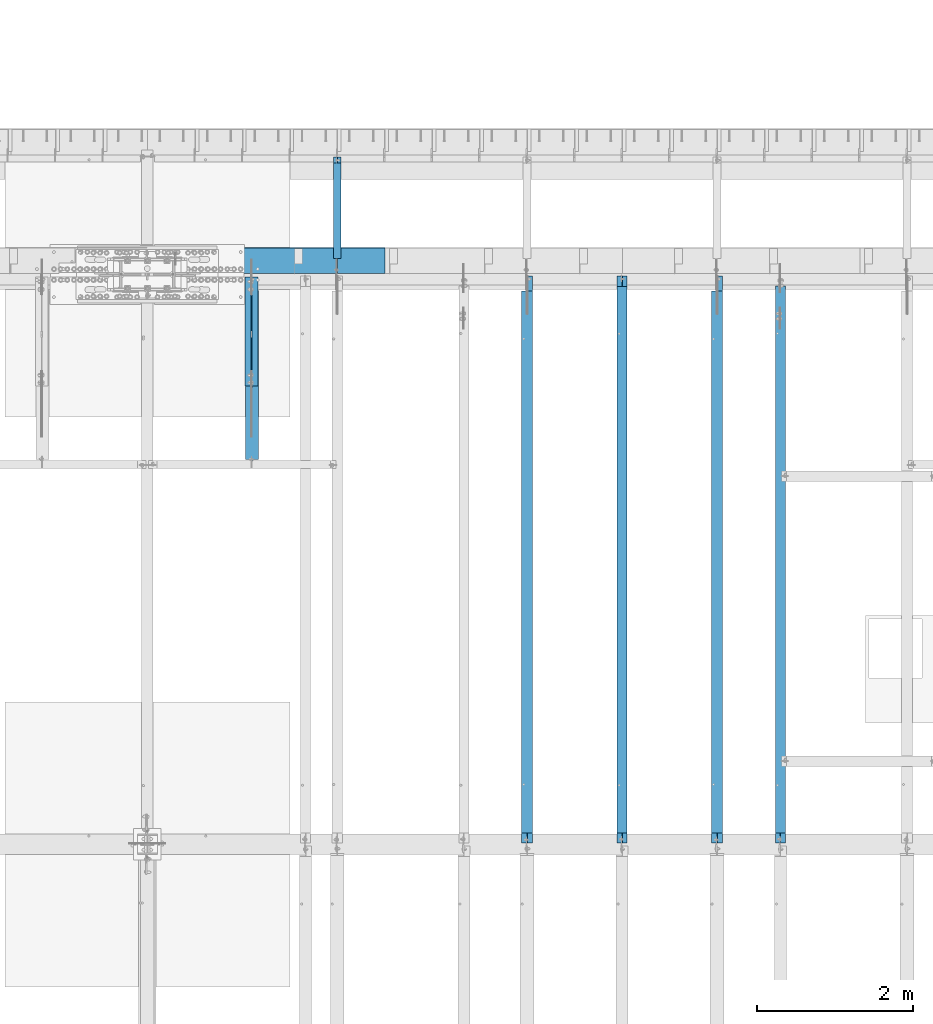
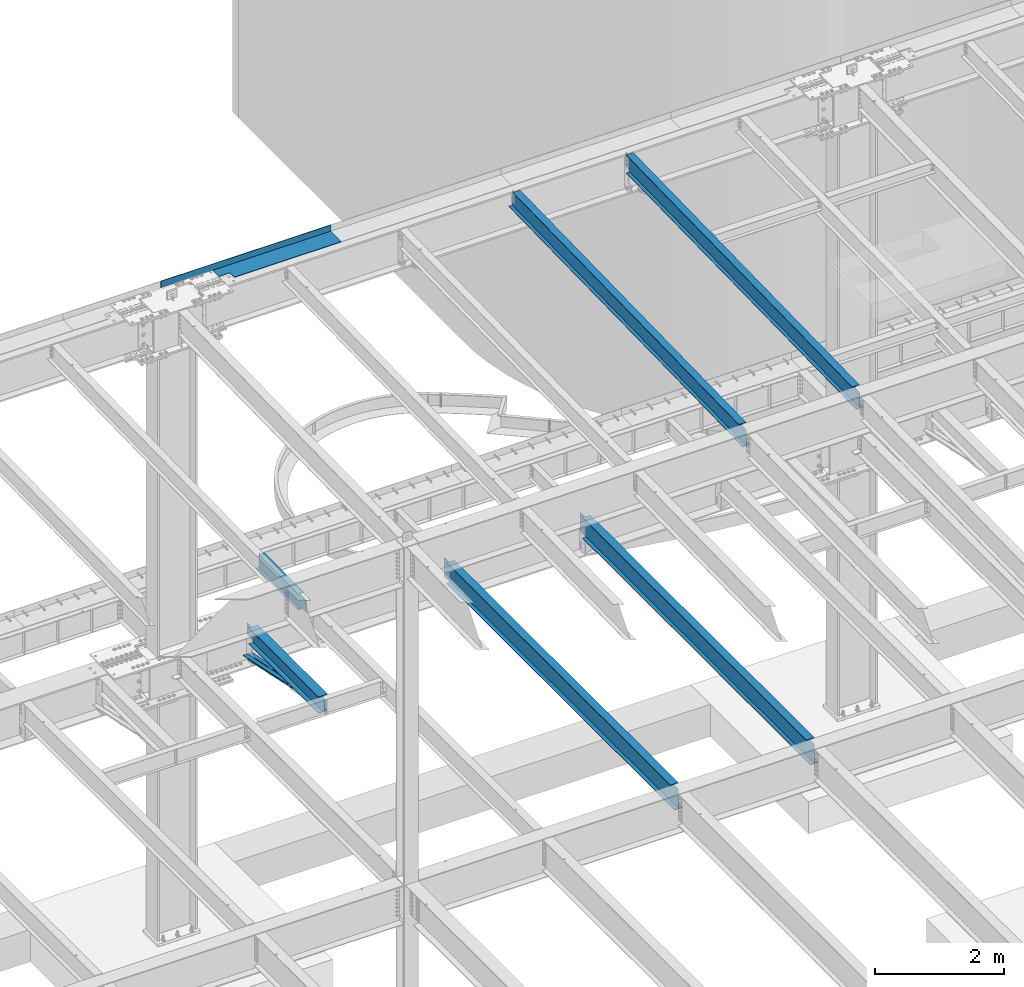
# One storey, part 1133 of 1763: 9 beams, 8 elements without a shape of their own.
"""IFC2X3 building model written with IfcOpenShell, lengths in millimetres."""

from ifc_helpers import new_model, si_unit, frame, origin_with_axes, place, context, subcontext, project, spatial, faceted_brep, material, type_object, element, aggregate, save


model = new_model("IFC2X3")

# Units and contexts
model_context = context("Model", 3, precision=1e-05, world=origin_with_axes())
body_context = subcontext(model_context, "Body", "Model", "MODEL_VIEW")
ifc_project = project(units=[si_unit("LENGTHUNIT", "METRE", prefix="MILLI"), si_unit("AREAUNIT", "SQUARE_METRE"), si_unit("VOLUMEUNIT", "CUBIC_METRE"), si_unit("MASSUNIT", "GRAM", prefix="KILO"), si_unit("TIMEUNIT", "SECOND"), si_unit("PLANEANGLEUNIT", "RADIAN"), si_unit("SOLIDANGLEUNIT", "STERADIAN"), si_unit("THERMODYNAMICTEMPERATUREUNIT", "DEGREE_CELSIUS"), si_unit("LUMINOUSINTENSITYUNIT", "LUMEN")], contexts=[model_context])

# Site, building, storey
site_placement = place(None, origin_with_axes())
site = spatial("IfcSite", under=ifc_project, at=site_placement, CompositionType="ELEMENT")
building_placement = place(site_placement, origin_with_axes())
building = spatial("IfcBuilding", under=site, at=building_placement, Name="Undefined", CompositionType="ELEMENT")
storey_placement = place(building_placement, origin_with_axes())
storey = spatial("IfcBuildingStorey", under=building, at=storey_placement, Name="Undefined", CompositionType="ELEMENT", Elevation=0.0)

# Assembly, beam
assembly_1_placement = place(storey_placement, origin_with_axes())
assembly_1 = element("IfcElementAssembly", 1, at=assembly_1_placement, inside=storey, Name="BEAM", AssemblyPlace="NOTDEFINED", PredefinedType="RIGID_FRAME")
ifc_material_1 = material(Name="STEEL/A992")
beam_type_1 = type_object("IfcBeamType", Name="W16X26", PredefinedType="NOTDEFINED")
beam_1_placement = place(assembly_1_placement, frame((-54279.2372736983, 44805.6, 4994.275), z_axis=(0.0, 0.0, 1.0), x_axis=(0.0, 1.0, 0.0)))
beam_1 = element("IfcBeam", 2, at=beam_1_placement, type_object=beam_type_1, material=ifc_material_1, Name="BEAM", ObjectType="W16X26", context=body_context, shape_type="Brep", body=[
    faceted_brep([(7104.06248869727, 3.17500000000291, -190.5), (7104.06248869734, 3.17487653380522, -200.025), (7104.06247902929, 69.8499999999985, -200.025), (7104.06247902929, 69.8499999999985, -190.5), (7294.5625, 3.17500000000291, -190.5), (7294.5625, 3.17490415680368, -200.025), (146.04999924302, 3.17499999999927, 190.5), (146.04999924302, 69.8499999999985, 190.5), (7104.0625, 69.8499999999985, 190.5), (7104.0625, 3.17500000000291, 190.5), (146.04999943226, -69.8499999999985, 200.025), (146.04999943226, 69.8499999999985, 200.025), (146.04999943226, 3.17500000000291, 180.715001487731), (146.04999943226, -3.17500000000291, 180.715001487731), (146.04999924302, -3.17499999999927, 190.5), (146.04999924302, -69.8499999999985, 190.5), (145.083269509669, 3.17500000000291, 175.854921969685), (145.083269509669, -3.17500000000291, 175.854921969685), (142.330255609195, 3.17500000000291, 171.734745501532), (142.330255609195, -3.17500000000291, 171.734745501532), (138.210079141041, 3.17500000000291, 168.981731601053), (138.210079141041, -3.17500000000291, 168.981731601053), (133.349999622995, 3.17500000000291, 168.015001678466), (133.349999622995, -3.17500000000291, 168.015001678466), (19.0499999999956, 3.17500000000291, 168.015001678466), (19.0499999999956, -3.17500000000291, 168.015001678466), (19.0499999999956, 3.17499999999927, -190.5), (19.0499999999956, 69.8499999999985, -190.5), (19.0499999999956, 69.8499999999985, -200.025), (19.0499999999956, -69.8499999999985, -200.025), (19.0499999999956, -69.8499999999985, -190.5), (19.0499999999956, -3.17499999999927, -190.5), (7294.5625, -69.8499999999985, -200.025), (7294.5625, -69.8499999999985, -190.5), (7294.5625, -3.17500000000291, -190.5), (7111.90242029122, -3.17500000000291, 156.541729922587), (7107.78224382307, -3.17500000000291, 159.294743823066), (7105.02922992258, -3.17500000000291, 163.414920291219), (7104.0625, -3.17500000000291, 168.274999809265), (7104.0625, -3.17500000000291, 190.5), (7294.5625, -3.17500000000291, 155.575), (7116.76249980927, -3.17500000000291, 155.575), (7104.0625, -69.8499999999985, 190.5), (7104.0625, -69.8499999999985, 200.025), (7104.0625, 69.8499999999985, 200.025), (7104.0625, 3.17500000000291, 168.274999809265), (7105.02922992258, 3.17500000000291, 163.414920291219), (7107.78224382307, 3.17500000000291, 159.294743823066), (7111.90242029122, 3.17500000000291, 156.541729922587), (7116.76249980927, 3.17500000000291, 155.575), (7294.5625, 3.17500000000291, 155.575), (7294.5625, 3.17500000000291, -184.976846570121)], [[[0, 1, 2, 3]], [[4, 5, 1, 0]], [[6, 7, 8, 9]], [[10, 11, 7, 6, 12, 13, 14, 15]], [[13, 12, 16, 17]], [[17, 16, 18, 19]], [[19, 18, 20, 21]], [[21, 20, 22, 23]], [[23, 22, 24, 25]], [[26, 27, 28, 29, 30, 31, 25, 24]], [[30, 29, 32, 33]], [[31, 30, 33, 34]], [[35, 36, 37, 38, 39, 14, 13, 17, 19, 21, 23, 25, 31, 34, 40, 41]], [[15, 14, 39, 42]], [[10, 15, 42, 43]], [[11, 10, 43, 44]], [[7, 11, 44, 8]], [[43, 42, 39, 38, 45, 9, 8, 44]], [[37, 46, 45, 38]], [[36, 47, 46, 37]], [[35, 48, 47, 36]], [[41, 49, 48, 35]], [[40, 50, 49, 41]], [[51, 4, 0, 26, 24, 22, 20, 18, 16, 12, 6, 9, 45, 46, 47, 48, 49, 50]], [[27, 26, 0, 3]], [[28, 27, 3, 2]], [[32, 29, 28, 2, 1, 5]], [[51, 50, 40, 34, 33, 32, 5, 4]]]),
])
aggregate(assembly_1, [beam_1])

assembly_2_placement = place(storey_placement, origin_with_axes())
assembly_2 = element("IfcElementAssembly", 3, at=assembly_2_placement, inside=storey, Name="BEAM", AssemblyPlace="NOTDEFINED", PredefinedType="RIGID_FRAME")
beam_2_placement = place(assembly_2_placement, frame((-56717.6372736983, 44805.6, 4994.275), z_axis=(0.0, 0.0, 1.0), x_axis=(0.0, 1.0, 0.0)))
beam_2 = element("IfcBeam", 4, at=beam_2_placement, type_object=beam_type_1, material=ifc_material_1, Name="BEAM", ObjectType="W16X26", context=body_context, shape_type="Brep", body=[
    faceted_brep([(7104.06248869727, 3.17500000000291, -190.5), (7104.06248869734, 3.17487653380522, -200.025), (7104.06247902929, 69.8499999999985, -200.025), (7104.06247902929, 69.8499999999985, -190.5), (7294.5625, 3.17500000000291, -190.5), (7294.5625, 3.17490415680368, -200.025), (146.04999924302, 3.17499999999927, 190.5), (146.04999924302, 69.8499999999985, 190.5), (7104.0625, 69.8499999999985, 190.5), (7104.0625, 3.17500000000291, 190.5), (146.04999943226, -69.8499999999985, 200.025), (146.04999943226, 69.8499999999985, 200.025), (146.04999943226, 3.17500000000291, 180.715001487731), (146.04999943226, -3.17500000000291, 180.715001487731), (146.04999924302, -3.17499999999927, 190.5), (146.04999924302, -69.8499999999985, 190.5), (145.083269509669, 3.17500000000291, 175.854921969685), (145.083269509669, -3.17500000000291, 175.854921969685), (142.330255609195, 3.17500000000291, 171.734745501532), (142.330255609195, -3.17500000000291, 171.734745501532), (138.210079141041, 3.17500000000291, 168.981731601053), (138.210079141041, -3.17500000000291, 168.981731601053), (133.349999622995, 3.17500000000291, 168.015001678466), (133.349999622995, -3.17500000000291, 168.015001678466), (19.0499999999956, 3.17500000000291, 168.015001678466), (19.0499999999956, -3.17500000000291, 168.015001678466), (19.0499999999956, 3.17499999999927, -190.5), (19.0499999999956, 69.8499999999985, -190.5), (19.0499999999956, 69.8499999999985, -200.025), (19.0499999999956, -69.8499999999985, -200.025), (19.0499999999956, -69.8499999999985, -190.5), (19.0499999999956, -3.17499999999927, -190.5), (7294.5625, -69.8499999999985, -200.025), (7294.5625, -69.8499999999985, -190.5), (7294.5625, -3.17500000000291, -190.5), (7111.90242029122, -3.17500000000291, 156.541729922587), (7107.78224382307, -3.17500000000291, 159.294743823066), (7105.02922992258, -3.17500000000291, 163.414920291219), (7104.0625, -3.17500000000291, 168.274999809265), (7104.0625, -3.17500000000291, 190.5), (7294.5625, -3.17500000000291, 155.575), (7116.76249980927, -3.17500000000291, 155.575), (7104.0625, -69.8499999999985, 190.5), (7104.0625, -69.8499999999985, 200.025), (7104.0625, 69.8499999999985, 200.025), (7104.0625, 3.17500000000291, 168.274999809265), (7105.02922992258, 3.17500000000291, 163.414920291219), (7107.78224382307, 3.17500000000291, 159.294743823066), (7111.90242029122, 3.17500000000291, 156.541729922587), (7116.76249980927, 3.17500000000291, 155.575), (7294.5625, 3.17500000000291, 155.575), (7294.5625, 3.17500000000291, -184.976846570121)], [[[0, 1, 2, 3]], [[4, 5, 1, 0]], [[6, 7, 8, 9]], [[10, 11, 7, 6, 12, 13, 14, 15]], [[13, 12, 16, 17]], [[17, 16, 18, 19]], [[19, 18, 20, 21]], [[21, 20, 22, 23]], [[23, 22, 24, 25]], [[26, 27, 28, 29, 30, 31, 25, 24]], [[30, 29, 32, 33]], [[31, 30, 33, 34]], [[35, 36, 37, 38, 39, 14, 13, 17, 19, 21, 23, 25, 31, 34, 40, 41]], [[15, 14, 39, 42]], [[10, 15, 42, 43]], [[11, 10, 43, 44]], [[7, 11, 44, 8]], [[43, 42, 39, 38, 45, 9, 8, 44]], [[37, 46, 45, 38]], [[36, 47, 46, 37]], [[35, 48, 47, 36]], [[41, 49, 48, 35]], [[40, 50, 49, 41]], [[51, 4, 0, 26, 24, 22, 20, 18, 16, 12, 6, 9, 45, 46, 47, 48, 49, 50]], [[27, 26, 0, 3]], [[28, 27, 3, 2]], [[32, 29, 28, 2, 1, 5]], [[51, 50, 40, 34, 33, 32, 5, 4]]]),
])
aggregate(assembly_2, [beam_2])

assembly_3_placement = place(storey_placement, origin_with_axes())
assembly_3 = element("IfcElementAssembly", 5, at=assembly_3_placement, inside=storey, Name="BEAM", AssemblyPlace="NOTDEFINED", PredefinedType="RIGID_FRAME")
beam_type_2 = type_object("IfcBeamType", Name="W14X22", PredefinedType="NOTDEFINED")
beam_3_placement = place(assembly_3_placement, frame((-53466.4372736983, 44809.2121579121, 11421.5633921212), z_axis=(0.0, -0.0206852279954837, 0.999786037781472), x_axis=(0.0, 0.999786037781472, 0.0206852279954825)))
beam_3 = element("IfcBeam", 6, at=beam_3_placement, type_object=beam_type_2, material=ifc_material_1, Name="BEAM", ObjectType="W14X22", context=body_context, shape_type="Brep", body=[
    faceted_brep([(7162.77359555585, -3.17500000000291, -166.687500001777), (7162.77359555585, -63.5, -166.687500001777), (7162.77359555585, -63.5, -174.625000001772), (7162.77359555585, 63.5, -174.625000001772), (7162.77359555585, 63.5, -166.687500001777), (7162.77359555585, 3.17500000000291, -166.687500001777), (7162.77359555586, 3.17500000000291, -155.574999838074), (7162.77359555586, -3.17500000000291, -155.574999838074), (7163.74032547845, 3.17500000000291, -150.714920320039), (7163.74032547845, -3.17500000000291, -150.714920320039), (7166.49333937895, 3.17500000000291, -146.594743851894), (7166.49333937895, -3.17500000000291, -146.594743851894), (7170.61351584714, 3.17500000000291, -143.841729951426), (7170.61351584714, -3.17500000000291, -143.841729951426), (7175.47359536523, 3.17500000000291, -142.87500002884), (7175.47359536523, -3.17500000000291, -142.87500002884), (7289.55462988591, -3.17500000000291, -142.875000028898), (7289.55462988591, 3.17500000000291, -142.875000028898), (148.791145859177, 3.17500000000291, 166.687499999833), (148.791145859177, 63.5, 166.687499999833), (7169.123595556, 63.5, 166.68749999797), (7169.123595556, 3.17500000000291, 166.68749999797), (11.9924390219312, 3.17500000000291, -166.687499999878), (11.9924390219312, 63.5, -166.687499999878), (11.8282148869548, 63.5, -174.624999999871), (11.8282148869548, -63.5, -174.624999999871), (11.9924390219312, -63.5, -166.687499999878), (11.9924390219312, -3.17500000000291, -166.687499999878), (17.9976630864912, -3.17500000000291, 123.56500167838), (17.9976630864912, 3.17500000000291, 123.56500167838), (136.091146049795, -3.17500000000291, 123.565001678358), (136.091146049795, 3.17500000000291, 123.565001678358), (140.951225567893, -3.17500000000291, 124.531731600942), (140.951225567893, 3.17500000000291, 124.531731600942), (145.071402036083, -3.17500000000291, 127.284745501414), (145.071402036083, 3.17500000000291, 127.284745501414), (147.824415936586, -3.17500000000291, 131.404921969557), (147.824415936586, 3.17500000000291, 131.404921969557), (148.791145859177, -3.17500000000291, 136.265001487593), (148.791145859177, 3.17500000000291, 136.265001487593), (148.79114585917, -63.5, 174.624999999827), (148.79114585917, 63.5, 174.624999999827), (148.791145859177, -3.17500000000291, 166.687499999833), (148.791145859177, -63.5, 166.687499999833), (7169.123595556, -3.17500000000291, 166.68749999797), (7169.123595556, -63.5, 166.68749999797), (7169.123595556, -63.5, 174.624999997965), (7169.123595556, 63.5, 174.624999997965), (7169.123595556, -3.17500000000291, 142.875000542512), (7169.123595556, 3.17500000000291, 142.875000542512), (7170.0903254786, -3.17500000000291, 138.014921024478), (7170.0903254786, 3.17500000000291, 138.014921024478), (7172.8433393791, -3.17500000000291, 133.894744556334), (7172.8433393791, 3.17500000000291, 133.894744556334), (7176.96351584728, -3.17500000000291, 131.14173065586), (7176.96351584728, 3.17500000000291, 131.14173065586), (7181.82359536537, -3.17500000000291, 130.175000733272), (7181.82359536537, 3.17500000000291, 130.175000733272), (7295.20394014482, -3.17500000000291, 130.17500073325), (7295.20394014482, 3.17500000000291, 130.17500073325)], [[[0, 1, 2, 3, 4, 5, 6, 7]], [[7, 6, 8, 9]], [[9, 8, 10, 11]], [[11, 10, 12, 13]], [[13, 12, 14, 15]], [[16, 15, 14, 17]], [[18, 19, 20, 21]], [[22, 23, 24, 25, 26, 27, 28, 29]], [[30, 31, 29, 28]], [[32, 33, 31, 30]], [[34, 35, 33, 32]], [[36, 37, 35, 34]], [[38, 39, 37, 36]], [[40, 41, 19, 18, 39, 38, 42, 43]], [[43, 42, 44, 45]], [[40, 43, 45, 46]], [[41, 40, 46, 47]], [[19, 41, 47, 20]], [[46, 45, 44, 48, 49, 21, 20, 47]], [[50, 51, 49, 48]], [[52, 53, 51, 50]], [[54, 55, 53, 52]], [[56, 57, 55, 54]], [[58, 59, 57, 56]], [[59, 58, 16, 17]], [[12, 10, 8, 6, 5, 22, 29, 31, 33, 35, 37, 39, 18, 21, 49, 51, 53, 55, 57, 59, 17, 14]], [[23, 22, 5, 4]], [[24, 23, 4, 3]], [[25, 24, 3, 2]], [[26, 25, 2, 1]], [[27, 26, 1, 0]], [[58, 56, 54, 52, 50, 48, 44, 42, 38, 36, 34, 32, 30, 28, 27, 0, 7, 9, 11, 13, 15, 16]]]),
])
aggregate(assembly_3, [beam_3])

assembly_4_placement = place(storey_placement, origin_with_axes())
assembly_4 = element("IfcElementAssembly", 7, at=assembly_4_placement, inside=storey, Name="BEAM", AssemblyPlace="NOTDEFINED", PredefinedType="RIGID_FRAME")
beam_4_placement = place(assembly_4_placement, frame((-55498.4372736983, 44809.2121579121, 11421.5633921212), z_axis=(0.0, -0.0206852279954837, 0.999786037781472), x_axis=(0.0, 0.999786037781472, 0.0206852279954825)))
beam_4 = element("IfcBeam", 8, at=beam_4_placement, type_object=beam_type_2, material=ifc_material_1, Name="BEAM", ObjectType="W14X22", context=body_context, shape_type="Brep", body=[
    faceted_brep([(136.091146049795, -3.17500000000291, 123.565001678358), (136.091146049795, 3.17500000000291, 123.565001678358), (17.9976630864912, 3.17500000000291, 123.56500167838), (17.9976630864912, -3.17500000000291, 123.56500167838), (140.951225567893, -3.17500000000291, 124.531731600942), (140.951225567893, 3.17500000000291, 124.531731600942), (145.071402036083, -3.17500000000291, 127.284745501414), (145.071402036083, 3.17500000000291, 127.284745501414), (147.824415936586, -3.17500000000291, 131.404921969557), (147.824415936586, 3.17500000000291, 131.404921969557), (148.791145859177, -3.17500000000291, 136.265001487593), (148.791145859177, 3.17500000000291, 136.265001487593), (148.79114585917, -63.5, 174.624999999827), (148.79114585917, 63.5, 174.624999999827), (148.791145859177, 63.5, 166.687499999833), (148.791145859177, 3.17500000000291, 166.687499999833), (148.791145859177, -3.17500000000291, 166.687499999833), (148.791145859177, -63.5, 166.687499999833), (11.9924390219312, -3.17500000000291, -166.687499999878), (11.9924390219312, -63.5, -166.687499999878), (7289.06195724197, -63.5, -166.687500001812), (7289.06195724197, -3.17500000000291, -166.687500001812), (11.8282148869548, -63.5, -174.624999999871), (7288.89773310699, -63.5, -174.625000001806), (11.8282148869548, 63.5, -174.624999999871), (7288.89773310699, 63.5, -174.625000001806), (11.9924390219312, 63.5, -166.687499999878), (7289.06195724197, 63.5, -166.687500001812), (11.9924390219312, 3.17500000000291, -166.687499999878), (7289.06195724197, 3.17500000000291, -166.687500001812), (7294.93580191941, 3.17500000000291, 117.21499785159), (7294.93580191941, -3.17500000000291, 117.21499785159), (7178.21066392501, 3.17500000000291, 117.214997851612), (7178.21066392501, -3.17500000000291, 117.214997851612), (7173.35058440694, 3.17500000000291, 118.181727774199), (7173.35058440694, -3.17500000000291, 118.181727774199), (7169.23040793875, 3.17500000000291, 120.934741674671), (7169.23040793875, -3.17500000000291, 120.934741674671), (7166.47739403824, 3.17500000000291, 125.054918142816), (7166.47739403824, -3.17500000000291, 125.054918142816), (7165.51066411565, 3.17500000000291, 129.91499766085), (7165.51066411565, -3.17500000000291, 129.91499766085), (7165.51066411565, -63.5, 174.624999997965), (7165.51066411565, -63.5, 166.68749999797), (7165.51066411565, -3.17500000000291, 166.68749999797), (7165.51066411565, 3.17500000000291, 166.68749999797), (7165.51066411565, 63.5, 166.68749999797), (7165.51066411565, 63.5, 174.624999997965)], [[[0, 1, 2, 3]], [[4, 5, 1, 0]], [[6, 7, 5, 4]], [[8, 9, 7, 6]], [[10, 11, 9, 8]], [[12, 13, 14, 15, 11, 10, 16, 17]], [[18, 19, 20, 21]], [[19, 22, 23, 20]], [[22, 24, 25, 23]], [[24, 26, 27, 25]], [[26, 28, 29, 27]], [[21, 20, 23, 25, 27, 29, 30, 31]], [[31, 30, 32, 33]], [[33, 32, 34, 35]], [[35, 34, 36, 37]], [[37, 36, 38, 39]], [[39, 38, 40, 41]], [[42, 43, 44, 41, 40, 45, 46, 47]], [[43, 42, 12, 17]], [[44, 43, 17, 16]], [[8, 6, 4, 0, 3, 18, 21, 31, 33, 35, 37, 39, 41, 44, 16, 10]], [[28, 26, 24, 22, 19, 18, 3, 2]], [[45, 40, 38, 36, 34, 32, 30, 29, 28, 2, 1, 5, 7, 9, 11, 15]], [[46, 45, 15, 14]], [[47, 46, 14, 13]], [[42, 47, 13, 12]]]),
])
aggregate(assembly_4, [beam_4])

# Assembly, beams
assembly_5_placement = place(storey_placement, origin_with_axes())
assembly_5 = element("IfcElementAssembly", 9, at=assembly_5_placement, inside=storey, Name="ANGLE BRACE", AssemblyPlace="NOTDEFINED", PredefinedType="RIGID_FRAME")
ifc_material_2 = material(Name="STEEL/A36")
beam_type_3 = type_object("IfcBeamType", Name="L4X3X5/16", PredefinedType="NOTDEFINED")
beam_5_placement = place(assembly_5_placement, frame((-60299.0372736984, 50680.4564530846, 4820.75267554856), z_axis=(0.0, -0.2072236520035, -0.978293595016513), x_axis=(0.0, 0.978293600950479, -0.20722362398951)))
beam_5 = element("IfcBeam", 10, at=beam_5_placement, type_object=beam_type_3, material=ifc_material_2, Name="ANGLE BRACE", ObjectType="L4X3X5/16", context=body_context, shape_type="Brep", body=[
    faceted_brep([(1.45519152283669e-10, 38.0999999999985, -50.7999999999993), (1.45519152283669e-10, 38.0999999999985, 50.7999999999993), (1427.42255777739, 38.0999999999985, 50.7999999995518), (1427.42255777754, 38.0999999999985, -50.8000000004868), (-7.27595761418343e-11, 30.1624999999985, 50.8000000000211), (1427.42255777739, 30.1624999999985, 50.7999999995518), (7.27595761418343e-11, 30.1624999999985, -42.8625000000175), (1427.42255777754, 30.1624999999985, -42.8625000004868), (7.27595761418343e-11, -38.0999999999985, -42.8625000000175), (1427.42255777754, -38.0999999999985, -42.8625000004868), (-1.23691279441118e-10, -38.1000000000022, -50.7999999999993), (1427.42255777754, -38.0999999999985, -50.8000000004868)], [[[0, 1, 2, 3]], [[1, 4, 5, 2]], [[4, 6, 7, 5]], [[6, 8, 9, 7]], [[8, 10, 11, 9]], [[10, 0, 3, 11]], [[5, 7, 9, 11, 3, 2]], [[10, 8, 6, 4, 1, 0]]]),
])
beam_6_placement = place(assembly_5_placement, frame((-60213.3122736983, 52076.9355387112, 4524.94833056974), z_axis=(0.0, -0.2072236520035, -0.978293595016513), x_axis=(0.0, -0.978293595016513, 0.207223652003498)))
beam_6 = element("IfcBeam", 11, at=beam_6_placement, type_object=beam_type_3, material=ifc_material_2, Name="ANGLE BRACE", ObjectType="L4X3X5/16", context=body_context, shape_type="Brep", body=[
    faceted_brep([(1.45519152283669e-10, 38.0999999999985, -50.7999999999993), (1.45519152283669e-10, 38.0999999999985, 50.7999999999993), (1427.46422513096, 38.0999999999985, 50.7999999991189), (1427.46422513096, 38.0999999999985, -50.8000000008396), (-7.27595761418343e-11, 30.1624999999985, 50.8000000000211), (1427.46422513096, 30.1624999999985, 50.7999999991189), (7.27595761418343e-11, 30.1624999999985, -42.8625000000175), (1427.46422513096, 30.1624999999985, -42.8625000008433), (7.27595761418343e-11, -38.0999999999985, -42.8625000000175), (1427.46422513096, -38.0999999999985, -42.8625000008433), (-1.23691279441118e-10, -38.1000000000022, -50.7999999999993), (1427.46422513096, -38.0999999999985, -50.8000000008396)], [[[0, 1, 2, 3]], [[1, 4, 5, 2]], [[4, 6, 7, 5]], [[6, 8, 9, 7]], [[8, 10, 11, 9]], [[10, 0, 3, 11]], [[5, 7, 9, 11, 3, 2]], [[10, 8, 6, 4, 1, 0]]]),
])
aggregate(assembly_5, [beam_5, beam_6])

# Assembly, beam
assembly_6_placement = place(storey_placement, origin_with_axes())
assembly_6 = element("IfcElementAssembly", 12, at=assembly_6_placement, inside=storey, Name="BEAM", AssemblyPlace="NOTDEFINED", PredefinedType="RIGID_FRAME")
beam_type_4 = type_object("IfcBeamType", PredefinedType="NOTDEFINED")
beam_7_placement = place(assembly_6_placement, frame((-60067.2617736983, 52133.5000002128, 11752.2624917654), z_axis=(-1.0, 0.0, 0.0), x_axis=(0.0, 1.0, 0.0)))
beam_7 = element("IfcBeam", 13, at=beam_7_placement, type_object=beam_type_4, material=ifc_material_2, Name="BENT_PLATE", context=body_context, shape_type="Brep", body=[
    faceted_brep([(133.349999999999, -4.76250000000073, 395.288085937507), (133.349999999999, 4.76250000000073, 395.288085937507), (0.0, 4.76250000000073, 395.288085937507), (0.0, -4.76250000000073, 395.288085937507), (133.349999999999, -4.76250000000073, 598.487976074226), (133.349999999999, 4.76250000000073, 598.487976074226), (327.024987792975, -4.76250000000073, 598.487976074226), (327.02498779296, 4.76250000000073, 598.487976074226), (327.024987792967, -4.76250000000073, 1524.00000000001), (327.024987792967, 4.76250000000073, 1524.0), (327.024987792975, -4.76250000000073, -1524.0), (0.0, -4.76249999999982, -1524.0), (0.0, 4.76249999999982, -1524.0), (336.549987792969, 4.76250000000073, -1524.0), (336.549987792969, -122.237499999999, -1524.0), (327.024987792975, -122.237499999999, -1524.0), (336.549987792969, 4.76250000000073, 1524.0), (336.549987792969, -122.237499999999, 1524.0), (327.024987792975, -122.237499999999, 1524.0), (327.024987792975, -99.5375007629373, 1524.0)], [[[0, 1, 2, 3]], [[4, 5, 1, 0]], [[6, 7, 5, 4]], [[8, 9, 7, 6]], [[10, 11, 12, 13, 14, 15]], [[13, 16, 17, 14]], [[18, 15, 14, 17]], [[19, 8, 6, 10, 15, 18]], [[0, 3, 11, 10, 6, 4]], [[12, 11, 3, 2]], [[16, 13, 12, 2, 1, 5, 7, 9]], [[19, 18, 17, 16, 9, 8]]]),
])
aggregate(assembly_6, [beam_7])

assembly_7_placement = place(storey_placement, origin_with_axes())
assembly_7 = element("IfcElementAssembly", 14, at=assembly_7_placement, inside=storey, Name="BEAM", AssemblyPlace="NOTDEFINED", PredefinedType="RIGID_FRAME")
beam_type_5 = type_object("IfcBeamType", Name="W12X16", PredefinedType="NOTDEFINED")
beam_8_placement = place(assembly_7_placement, frame((-59156.0372736983, 52120.8, 5041.9), z_axis=(0.0, 0.0, 1.0), x_axis=(0.0, 1.0, 0.0)))
beam_8 = element("IfcBeam", 15, at=beam_8_placement, type_object=beam_type_5, material=ifc_material_1, Name="BEAM", ObjectType="W12X16", context=body_context, shape_type="Brep", body=[
    faceted_brep([(20.6374999999971, -3.17500000000291, -114.3), (20.6374999999971, 3.17500000000291, -114.3), (192.087500190733, 3.17500000000291, -114.3), (192.087500190733, -3.17500000000291, -114.3), (196.94757970878, 3.17500000000291, -115.266729922588), (196.94757970878, -3.17500000000291, -115.266729922588), (201.067756176933, 3.17500000000291, -118.019743823066), (201.067756176933, -3.17500000000291, -118.019743823066), (203.820770077407, 3.17500000000291, -122.13992029122), (203.820770077407, -3.17500000000291, -122.13992029122), (204.787499999999, -3.17500000000291, -126.999999809265), (204.787499999999, 3.17500000000291, -126.999999809265), (204.787499999999, 3.17500000000291, -146.05), (204.787499999999, 50.8000000000029, -146.05), (204.787499999999, 50.8000000000029, -152.4), (204.787499999999, -50.8000000000029, -152.4), (204.787499999999, -50.8000000000029, -146.05), (204.787499999999, -3.17500000000291, -146.05), (1431.13125000001, 50.8000000000029, 146.05), (1431.13125000001, 3.17500000000291, 146.05), (204.787499999999, 3.17500000000291, 146.05), (204.787499999999, 50.8000000000029, 146.05), (192.087500190733, -3.17500000000291, 114.3), (192.087500190733, 3.17500000000291, 114.3), (20.6374999999971, 3.17500000000291, 114.3), (20.6374999999971, -3.17500000000291, 114.3), (196.94757970878, -3.17500000000291, 115.266729922588), (196.94757970878, 3.17500000000291, 115.266729922588), (201.067756176933, -3.17500000000291, 118.019743823066), (201.067756176933, 3.17500000000291, 118.019743823066), (203.820770077407, -3.17500000000291, 122.13992029122), (203.820770077407, 3.17500000000291, 122.13992029122), (204.787499999999, -3.17500000000291, 126.999999809265), (204.787499999999, 3.17500000000291, 126.999999809265), (1431.13125000001, -50.8000000000029, 152.4), (1431.13125000001, 50.8000000000029, 152.4), (204.787499999999, 50.8000000000029, 152.4), (204.787499999999, -50.8000000000029, 152.4), (1431.13125000001, -50.8000000000029, 146.05), (204.787499999999, -50.8000000000029, 146.05), (1431.13125000001, -3.17500000000291, 146.05), (204.787499999999, -3.17500000000291, 146.05), (1431.13125000001, -3.17500000000291, 139.440001487732), (1431.13125000001, 3.17500000000291, 139.440001487732), (1432.0979799226, -3.17500000000291, 134.579921969686), (1432.0979799226, 3.17500000000291, 134.579921969686), (1434.85099382307, -3.17500000000291, 130.459745501533), (1434.85099382307, 3.17500000000291, 130.459745501533), (1438.97117029122, -3.17500000000291, 127.706731601054), (1438.97117029122, 3.17500000000291, 127.706731601054), (1443.83124980927, -3.17500000000291, 126.740001678467), (1443.83124980927, 3.17500000000291, 126.740001678467), (1507.33125, -3.17500000000291, 126.740001678467), (1507.33125, 3.17500000000291, 126.740001678467), (1507.33125, -3.17500000000291, -146.05), (1507.33125, -50.8000000000029, -146.05), (1507.33125, -50.8000000000029, -152.4), (1507.33125, 50.8000000000029, -152.4), (1507.33125, 50.8000000000029, -146.05), (1507.33125, 3.17500000000291, -146.05)], [[[0, 1, 2, 3]], [[3, 2, 4, 5]], [[5, 4, 6, 7]], [[7, 6, 8, 9]], [[10, 11, 12, 13, 14, 15, 16, 17]], [[9, 8, 11, 10]], [[18, 19, 20, 21]], [[22, 23, 24, 25]], [[26, 27, 23, 22]], [[28, 29, 27, 26]], [[30, 31, 29, 28]], [[32, 33, 31, 30]], [[34, 35, 36, 37]], [[38, 34, 37, 39]], [[40, 38, 39, 41]], [[37, 36, 21, 20, 33, 32, 41, 39]], [[35, 18, 21, 36]], [[34, 38, 40, 42, 43, 19, 18, 35]], [[44, 45, 43, 42]], [[46, 47, 45, 44]], [[48, 49, 47, 46]], [[50, 51, 49, 48]], [[52, 53, 51, 50]], [[54, 55, 56, 57, 58, 59, 53, 52]], [[55, 54, 17, 16]], [[56, 55, 16, 15]], [[57, 56, 15, 14]], [[58, 57, 14, 13]], [[59, 58, 13, 12]], [[6, 4, 2, 1, 24, 23, 27, 29, 31, 33, 20, 19, 43, 45, 47, 49, 51, 53, 59, 12, 11, 8]], [[25, 24, 1, 0]], [[54, 52, 50, 48, 46, 44, 42, 40, 41, 32, 30, 28, 26, 22, 25, 0, 3, 5, 7, 9, 10, 17]]]),
])
aggregate(assembly_7, [beam_8])

assembly_8_placement = place(storey_placement, origin_with_axes())
assembly_8 = element("IfcElementAssembly", 16, at=assembly_8_placement, inside=storey, Name="BEAM", AssemblyPlace="NOTDEFINED", PredefinedType="RIGID_FRAME")
beam_type_6 = type_object("IfcBeamType", Name="W12X26", PredefinedType="NOTDEFINED")
beam_9_placement = place(assembly_8_placement, frame((-60248.2372736984, 49682.4, 5038.725), z_axis=(0.0, 0.0, 1.0), x_axis=(0.0, 1.0, 0.0)))
beam_9 = element("IfcBeam", 17, at=beam_9_placement, type_object=beam_type_6, material=ifc_material_1, Name="BEAM", ObjectType="W12X26", context=body_context, shape_type="Brep", body=[
    faceted_brep([(2233.6125, -3.17500000000291, -146.05), (2233.6125, -82.5500000000029, -146.05), (2233.6125, -82.5500000000029, -155.575), (2233.6125, 82.5500000000029, -155.575), (2233.6125, 82.5500000000029, -146.05), (2233.6125, 3.17500000000291, -146.05), (2233.6125, 3.17500000000291, -123.824999809265), (2233.6125, -3.17500000000291, -123.824999809265), (2234.57922992259, 3.17500000000291, -118.96492029122), (2234.57922992259, -3.17500000000291, -118.96492029122), (2237.33224382307, 3.17500000000291, -114.844743823066), (2237.33224382307, -3.17500000000291, -114.844743823066), (2241.45242029122, 3.17500000000291, -112.091729922588), (2241.45242029122, -3.17500000000291, -112.091729922588), (2246.31249980927, 3.17500000000291, -111.125), (2246.31249980927, -3.17500000000291, -111.125), (2417.7625, -3.17500000000291, -111.125), (2417.7625, 3.17500000000291, -111.125), (65.8812499999913, 3.17500000000291, 146.05), (65.8812499999913, 82.5500000000029, 146.05), (2233.6125, 82.5500000000029, 146.05), (2233.6125, 3.17500000000291, 146.05), (65.8812499999913, -3.17500000000291, -123.824999809265), (65.8812499999913, 3.17500000000291, -123.824999809265), (65.8812499999913, 3.17500000000291, -146.05), (65.8812499999913, 82.5500000000029, -146.05), (65.8812499999913, 82.5500000000029, -155.575), (65.8812499999913, -82.5500000000029, -155.575), (65.8812499999913, -82.5500000000029, -146.05), (65.8812499999913, -3.17500000000291, -146.05), (64.9145200774001, -3.17500000000291, -118.96492029122), (64.9145200774001, 3.17500000000291, -118.96492029122), (62.1615061769262, -3.17500000000291, -114.844743823066), (62.1615061769262, 3.17500000000291, -114.844743823066), (58.0413297087725, -3.17500000000291, -112.091729922588), (58.0413297087725, 3.17500000000291, -112.091729922588), (53.1812501907261, -3.17500000000291, -111.125), (53.1812501907261, 3.17500000000291, -111.125), (15.0812499999956, -3.17500000000291, -111.125), (15.0812499999956, 3.17500000000291, -111.125), (15.0812499999956, -3.17500000000291, 117.475), (15.0812499999956, 3.17500000000291, 117.475), (53.1812501907261, -3.17500000000291, 117.475), (53.1812501907261, 3.17500000000291, 117.475), (58.0413297087725, -3.17500000000291, 118.441729922588), (58.0413297087725, 3.17500000000291, 118.441729922588), (62.1615061769262, -3.17500000000291, 121.194743823066), (62.1615061769262, 3.17500000000291, 121.194743823066), (64.9145200774001, -3.17500000000291, 125.31492029122), (64.9145200774001, 3.17500000000291, 125.31492029122), (65.8812499999913, -3.17500000000291, 130.174999809266), (65.8812499999913, 3.17500000000291, 130.174999809266), (65.8812499999913, -82.5500000000029, 155.575), (65.8812499999913, 82.5500000000029, 155.575), (65.8812499999913, -3.17500000000291, 146.05), (65.8812499999913, -82.5500000000029, 146.05), (2233.6125, -3.17500000000291, 146.05), (2233.6125, -82.5500000000029, 146.05), (2233.6125, -82.5500000000029, 155.575), (2233.6125, 82.5500000000029, 155.575), (2233.6125, -3.17500000000291, 123.824999809265), (2233.6125, 3.17500000000291, 123.824999809265), (2234.57922992259, -3.17500000000291, 118.96492029122), (2234.57922992259, 3.17500000000291, 118.96492029122), (2237.33224382307, -3.17500000000291, 114.844743823066), (2237.33224382307, 3.17500000000291, 114.844743823066), (2241.45242029122, -3.17500000000291, 112.091729922588), (2241.45242029122, 3.17500000000291, 112.091729922588), (2246.31249980927, -3.17500000000291, 111.125), (2246.31249980927, 3.17500000000291, 111.125), (2417.7625, -3.17500000000291, 111.125), (2417.7625, 3.17500000000291, 111.125)], [[[0, 1, 2, 3, 4, 5, 6, 7]], [[7, 6, 8, 9]], [[9, 8, 10, 11]], [[11, 10, 12, 13]], [[13, 12, 14, 15]], [[16, 15, 14, 17]], [[18, 19, 20, 21]], [[22, 23, 24, 25, 26, 27, 28, 29]], [[30, 31, 23, 22]], [[32, 33, 31, 30]], [[34, 35, 33, 32]], [[36, 37, 35, 34]], [[38, 39, 37, 36]], [[40, 41, 39, 38]], [[42, 43, 41, 40]], [[44, 45, 43, 42]], [[46, 47, 45, 44]], [[48, 49, 47, 46]], [[50, 51, 49, 48]], [[52, 53, 19, 18, 51, 50, 54, 55]], [[55, 54, 56, 57]], [[52, 55, 57, 58]], [[53, 52, 58, 59]], [[19, 53, 59, 20]], [[58, 57, 56, 60, 61, 21, 20, 59]], [[62, 63, 61, 60]], [[64, 65, 63, 62]], [[66, 67, 65, 64]], [[68, 69, 67, 66]], [[70, 71, 69, 68]], [[71, 70, 16, 17]], [[12, 10, 8, 6, 5, 24, 23, 31, 33, 35, 37, 39, 41, 43, 45, 47, 49, 51, 18, 21, 61, 63, 65, 67, 69, 71, 17, 14]], [[25, 24, 5, 4]], [[26, 25, 4, 3]], [[27, 26, 3, 2]], [[28, 27, 2, 1]], [[29, 28, 1, 0]], [[70, 68, 66, 64, 62, 60, 56, 54, 50, 48, 46, 44, 42, 40, 38, 36, 34, 32, 30, 22, 29, 0, 7, 9, 11, 13, 15, 16]]]),
])
aggregate(assembly_8, [beam_9])

save(model, "model.ifc")
